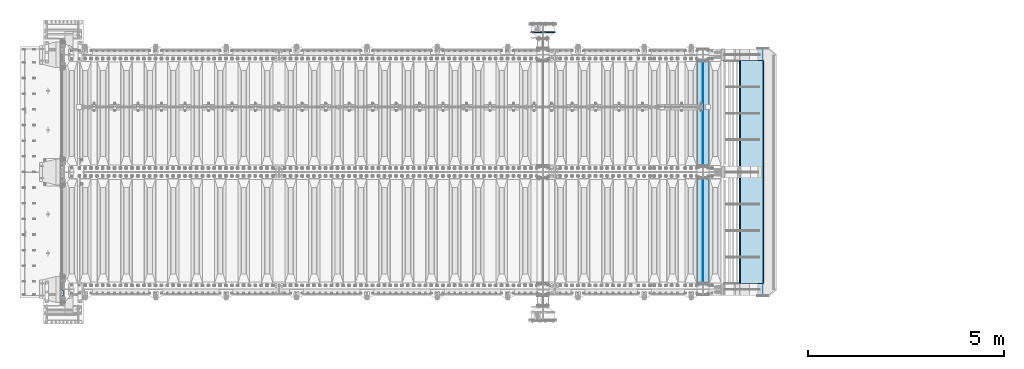
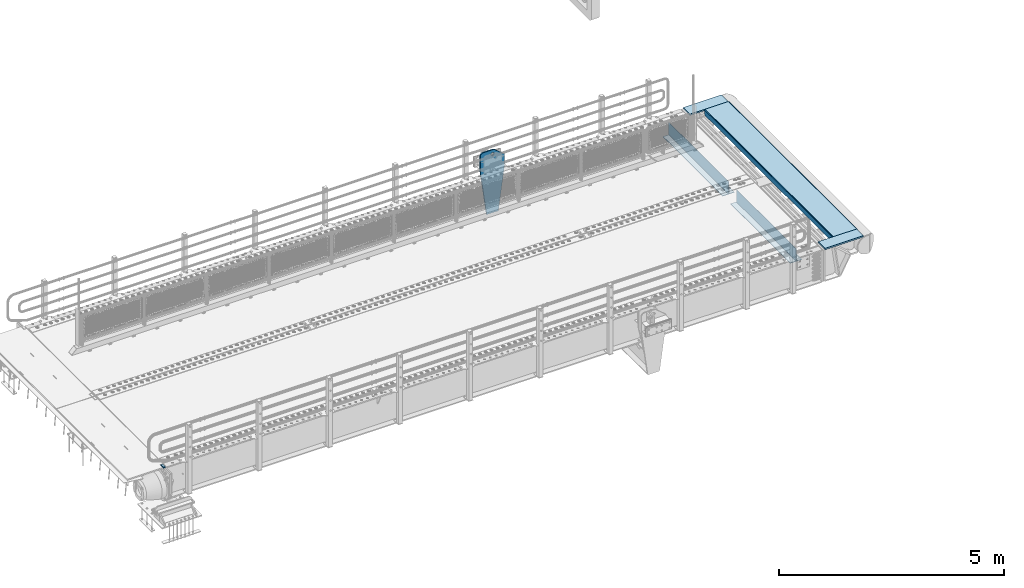
# One storey, part 165 of 208: 10 plates.
"""IFC2X3 building model written with IfcOpenShell, lengths in millimetres."""

import ifcopenshell
import ifcopenshell.guid

model = None  # the IFC model being written
_history = None  # IfcOwnerHistory: only IFC2X3 demands one
_inside = {}  # id of a spatial element -> (the spatial element, [elements in it])
_under = {}  # id of a project, library or spatial element -> (it, [spatial elements below it])
_declared = {}  # id of a project -> (the project, [libraries it declares])
_typed = {}  # id of a type object -> (the type object, [elements of that type])
_made_of = {}  # id of a material, layer set ... -> (it, [elements and type objects made of it])


def new_model(schema):
    """Start an empty IFC model of exactly this schema.

    Asked for "IFC4X3", IfcOpenShell would pick the latest addendum, in which some entities
    have other attributes; the version numbers below select the first issue.
    IFC2X3 requires an IfcOwnerHistory on every rooted entity: one is made here for all.
    """
    global model, _history
    if schema == "IFC4X3":
        model = ifcopenshell.file(schema_version=(4, 3, 0, 0))
    else:
        model = ifcopenshell.file(schema=schema)
    _inside.clear()
    _under.clear()
    _declared.clear()
    _typed.clear()
    _made_of.clear()
    _history = None
    if model.schema == "IFC2X3":
        org = make("IfcOrganization", Name="unknown")
        user = make(
            "IfcPersonAndOrganization",
            ThePerson=make("IfcPerson", FamilyName="unknown"),
            TheOrganization=org,
        )
        app = make(
            "IfcApplication",
            ApplicationDeveloper=org,
            Version="unknown",
            ApplicationFullName="unknown",
            ApplicationIdentifier="unknown",
        )
        _history = make(
            "IfcOwnerHistory",
            OwningUser=user,
            OwningApplication=app,
            ChangeAction="ADDED",
            CreationDate=0,
        )
    return model


def make(cls, **values):
    """One entity of the class cls with the attributes given. An attribute that is None is left unset."""
    return model.create_entity(
        cls, **{name: value for name, value in values.items() if value is not None}
    )


def rooted(cls, **values):
    """An entity with a GlobalId (a new one), such as an element, a storey or a relation."""
    return make(cls, GlobalId=ifcopenshell.guid.new(), OwnerHistory=_history, **values)


def si_unit(unit_type, name, prefix=None):
    """IfcSIUnit, for example si_unit("LENGTHUNIT", "METRE", prefix="MILLI")."""
    return make("IfcSIUnit", UnitType=unit_type, Prefix=prefix, Name=name)


def assignment(units):
    """IfcUnitAssignment: the units of a project."""
    return None if units is None else make("IfcUnitAssignment", Units=units)


def point(xyz):
    """IfcCartesianPoint."""
    return None if xyz is None else make("IfcCartesianPoint", Coordinates=xyz)


def direction(xyz):
    """IfcDirection."""
    return None if xyz is None else make("IfcDirection", DirectionRatios=xyz)


def frame(location, z_axis=None, x_axis=None):
    """IfcAxis2Placement3D, a coordinate frame: its origin and axes. An axis left out is left unset."""
    return make(
        "IfcAxis2Placement3D",
        Location=point(location),
        Axis=direction(z_axis),
        RefDirection=direction(x_axis),
    )


def origin_with_axes():
    """The frame at (0, 0, 0) with the z axis (0, 0, 1) and the x axis (1, 0, 0) written out."""
    return frame((0.0, 0.0, 0.0), z_axis=(0.0, 0.0, 1.0), x_axis=(1.0, 0.0, 0.0))


def place(relative_to, where):
    """IfcLocalPlacement: puts the frame where relative to a parent placement (None: the world)."""
    return make(
        "IfcLocalPlacement", PlacementRelTo=relative_to, RelativePlacement=where
    )


def context(
    kind, dimensions, precision=None, world=None, true_north=None, identifier=None
):
    """IfcGeometricRepresentationContext, for example the 3D "Model" context."""
    return make(
        "IfcGeometricRepresentationContext",
        ContextIdentifier=identifier,
        ContextType=kind,
        CoordinateSpaceDimension=dimensions,
        Precision=precision,
        WorldCoordinateSystem=world,
        TrueNorth=true_north,
    )


def subcontext(parent, identifier, kind, view, scale=None):
    """IfcGeometricRepresentationSubContext, for example "Body" below "Model"."""
    return make(
        "IfcGeometricRepresentationSubContext",
        ContextIdentifier=identifier,
        ContextType=kind,
        ParentContext=parent,
        TargetScale=scale,
        TargetView=view,
    )


def project(units=None, contexts=None):
    """IfcProject with its units and contexts."""
    return rooted(
        "IfcProject",
        Name="project",
        RepresentationContexts=contexts,
        UnitsInContext=assignment(units),
    )


def spatial(cls, under=None, at=None, **own):
    """A site, building, storey or space (cls), placed at a placement, below another one or the project."""
    s = rooted(cls, ObjectPlacement=at, **own)
    if under is not None:
        _under.setdefault(under.id(), (under, []))[1].append(s)
    return s


def faces_of(points, faces, orient=None, outer=None):
    """IfcFace entities. A face is a list of loops; a loop is a list of indices into points, from 0.

    orient and outer hold one flag for each loop. By default every Orientation is true, the
    first loop of a face is its IfcFaceOuterBound and the others are IfcFaceBound.
    """
    made = []
    for i, loops in enumerate(faces):
        bounds = []
        for j, loop in enumerate(loops):
            is_outer = j == 0 if outer is None else outer[i][j]
            bounds.append(
                make(
                    "IfcFaceOuterBound" if is_outer else "IfcFaceBound",
                    Bound=make("IfcPolyLoop", Polygon=[points[k] for k in loop]),
                    Orientation=True if orient is None else orient[i][j],
                )
            )
        made.append(make("IfcFace", Bounds=bounds))
    return made


def faceted_brep(points, faces, orient=None, outer=None, voids=None):
    """IfcFacetedBrep: a solid bounded by flat faces; with voids (closed shells), ...WithVoids."""
    shared = [point(p) for p in points]
    hull = make("IfcClosedShell", CfsFaces=faces_of(shared, faces, orient, outer))
    if voids is None:
        return make("IfcFacetedBrep", Outer=hull)
    return make(
        "IfcFacetedBrepWithVoids",
        Outer=hull,
        Voids=[
            make(cls, CfsFaces=faces_of(shared, fs, o, b)) for cls, fs, o, b in voids
        ],
    )


def shape(context_of_items, identifier, shape_type, items):
    """IfcShapeRepresentation: the items that make up one representation, for example the "Body"."""
    return make(
        "IfcShapeRepresentation",
        ContextOfItems=context_of_items,
        RepresentationIdentifier=identifier,
        RepresentationType=shape_type,
        Items=items,
    )


def material(Name=None, Category=None):
    """IfcMaterial."""
    return make("IfcMaterial", Name=Name, Category=Category)


def made_of(thing, what):
    """Note that an element or type object is made of a material, layer set ...; save() writes the relation."""
    if what is not None:
        _made_of.setdefault(what.id(), (what, []))[1].append(thing)
    return thing


def type_object(cls, material=None, **own):
    """A type object (cls), such as IfcWallType, which elements share."""
    return made_of(rooted(cls, **own), material)


def element(
    cls,
    number,
    at=None,
    inside=None,
    cuts=None,
    type_object=None,
    material=None,
    context=None,
    identifier="Body",
    shape_type=None,
    held_by="IfcProductDefinitionShape",
    body=None,
    shapes=None,
    **own,
):
    """One element of the class cls, such as IfcWall. Its Tag is "e" and its number.

    at: its placement. inside: the storey or other place that contains it. cuts: it is an
    opening in that element (IfcRelVoidsElement). A single representation is given by context,
    identifier, shape_type and body (its items); several are given by shapes. held_by: the class
    of the entity that holds the representations. save() writes the other relations.
    """
    e = rooted(cls, Tag="e%d" % number, ObjectPlacement=at, **own)
    if body is not None:
        shapes = [shape(context, identifier, shape_type, body)]
    if shapes is not None:
        e.Representation = make(held_by, Representations=shapes)
    if inside is not None:
        _inside.setdefault(inside.id(), (inside, []))[1].append(e)
    if cuts is not None:
        rooted(
            "IfcRelVoidsElement", RelatingBuildingElement=cuts, RelatedOpeningElement=e
        )
    if type_object is not None:
        _typed.setdefault(type_object.id(), (type_object, []))[1].append(e)
    return made_of(e, material)


def aggregate(whole, parts):
    """IfcRelAggregates: a whole, such as a stair, and the parts it consists of."""
    return rooted("IfcRelAggregates", RelatingObject=whole, RelatedObjects=parts)


def save(model, path):
    """Write the relations noted so far, then the file.

    IfcRelAggregates (storeys below a building ...), IfcRelContainedInSpatialStructure (elements
    in a storey), IfcRelDefinesByType, IfcRelAssociatesMaterial and IfcRelDeclares: one each for
    every whole, place, type object, material and project.
    """
    for whole, parts in _under.values():
        aggregate(whole, parts)
    for where, things in _inside.values():
        rooted(
            "IfcRelContainedInSpatialStructure",
            RelatedElements=things,
            RelatingStructure=where,
        )
    for kind, things in _typed.values():
        rooted("IfcRelDefinesByType", RelatedObjects=things, RelatingType=kind)
    for what, things in _made_of.values():
        rooted("IfcRelAssociatesMaterial", RelatedObjects=things, RelatingMaterial=what)
    for by, libraries in _declared.values():
        rooted("IfcRelDeclares", RelatingContext=by, RelatedDefinitions=libraries)
    model.write(path)


model = new_model("IFC2X3")

# Units and contexts
model_context = context("Model", 3, precision=1e-05, world=origin_with_axes())
body_context = subcontext(model_context, "Body", "Model", "MODEL_VIEW")
ifc_project = project(units=[si_unit("LENGTHUNIT", "METRE", prefix="MILLI"), si_unit("AREAUNIT", "SQUARE_METRE"), si_unit("VOLUMEUNIT", "CUBIC_METRE"), si_unit("MASSUNIT", "GRAM", prefix="KILO"), si_unit("TIMEUNIT", "SECOND"), si_unit("PLANEANGLEUNIT", "RADIAN"), si_unit("SOLIDANGLEUNIT", "STERADIAN"), si_unit("THERMODYNAMICTEMPERATUREUNIT", "DEGREE_CELSIUS"), si_unit("LUMINOUSINTENSITYUNIT", "LUMEN")], contexts=[model_context])

# Site, building, storey
site_placement = place(None, origin_with_axes())
site = spatial("IfcSite", under=ifc_project, at=site_placement, CompositionType="ELEMENT")
building_placement = place(site_placement, origin_with_axes())
building = spatial("IfcBuilding", under=site, at=building_placement, Name="Standard", CompositionType="ELEMENT")
storey_placement = place(building_placement, origin_with_axes())
storey = spatial("IfcBuildingStorey", under=building, at=storey_placement, Name="Undefined", CompositionType="ELEMENT", Elevation=0.0)

# Plates
ifc_material_1 = material()
plate_type_1 = type_object("IfcPlateType", PredefinedType="NOTDEFINED")
plate_1_placement = place(storey_placement, frame((-42460.00000006, -89.9999995680091, -15.9997623858373), z_axis=(-1.0, 0.0, 0.0), x_axis=(0.0, -4.95099999998473e-06, 0.999999999987744)))
element("IfcPlate", 1, at=plate_1_placement, inside=storey, type_object=plate_type_1, material=ifc_material_1, context=body_context, shape_type="Brep", body=[
    faceted_brep([(-1.77635683940025e-15, -60.0, 0.0), (-0.000933120085690575, -60.0, 60.0), (-0.000933120085690575, 60.0, 59.9999999999927), (-1.77635683940025e-15, 60.0, -7.27595761418343e-12), (24.9991450303709, -60.0, 60.0), (24.9991450303709, 60.0, 59.9999999999927), (26.544215218168, -60.0, 59.7552873850873), (26.544215218168, 60.0, 59.75528738508), (27.9380461396139, -60.0, 59.0451032459096), (27.9380461396139, 60.0, 59.0451032459096), (29.0442025908961, -60.0, 57.9389639895744), (29.0442025908961, 60.0, 57.9389639895744), (29.7544083969366, -60.0, 56.5451441080368), (29.7544083969366, 60.0, 56.5451441080295), (29.9991450297669, -60.0, 55.0000777244568), (29.9991450297669, 60.0, 55.0000777244495), (29.999922274335, -60.0, 5.00007772445679), (29.999922274335, 60.0, 5.00007772444951), (29.7552240705896, -60.0, 3.45497416452417), (29.7552240705896, 60.0, 3.45497416452417), (29.0450346578116, -60.0, 2.06111146690819), (29.0450346578116, 60.0, 2.06111146690819), (27.9388736885072, -60.0, 0.954933302316931), (27.9388736885072, 60.0, 0.954933302316931), (26.5450220308766, -60.0, 0.244722222181736), (26.5450220308766, 60.0, 0.244722222181736), (24.9999222749392, -60.0, 0.0), (24.9999222749392, 60.0, -7.27595761418343e-12)], [[[0, 1, 2, 3]], [[1, 4, 5, 2]], [[4, 6, 7, 5]], [[6, 8, 9, 7]], [[8, 10, 11, 9]], [[10, 12, 13, 11]], [[12, 14, 15, 13]], [[14, 16, 17, 15]], [[16, 18, 19, 17]], [[18, 20, 21, 19]], [[20, 22, 23, 21]], [[22, 24, 25, 23]], [[24, 26, 27, 25]], [[26, 0, 3, 27]], [[5, 7, 9, 11, 13, 15, 17, 19, 21, 23, 25, 27, 3, 2]], [[26, 24, 22, 20, 18, 16, 14, 12, 10, 8, 6, 4, 1, 0]]]),
])
ifc_material_2 = material(Name="STEEL/S355N")
plate_type_2 = type_object("IfcPlateType", PredefinedType="NOTDEFINED")
for number, where, z_axis, x_axis in (
    (2, (-26255.0, 175.0, -343.0), (0.0, 1.0, 0.0), (1.0, 0.0, 0.0)),
    (3, (-26255.0, 3175.0, -343.0), (0.0, 1.0, 0.0), (1.0, 0.0, 0.0)),
):
    element("IfcPlate", number, at=place(storey_placement, frame(where, z_axis=z_axis, x_axis=x_axis)), inside=storey, type_object=plate_type_2, material=ifc_material_2, context=body_context, shape_type="Brep", body=[
        faceted_brep([(0.0, -7.0, 0.0), (0.0, -7.0, 2650.0), (0.0, 7.0, 2650.0), (0.0, 7.0, 0.0), (300.0, -7.0, 2650.0), (300.0, 7.0, 2650.0), (300.0, -7.0, 0.0), (300.0, 7.0, 0.0)], [[[0, 1, 2, 3]], [[1, 4, 5, 2]], [[4, 6, 7, 5]], [[6, 0, 3, 7]], [[5, 7, 3, 2]], [[6, 4, 1, 0]]]),
    ])
plate_type_3 = type_object("IfcPlateType", PredefinedType="NOTDEFINED")
for number, where, z_axis, x_axis in (
    (4, (-26105.0, 2825.0, 0.0), (0.0, 0.0, -1.0), (0.0, -1.0, 0.0)),
    (5, (-26105.0, 5825.0, 0.0), (0.0, 0.0, -1.0), (0.0, -1.0, 0.0)),
):
    element("IfcPlate", number, at=place(storey_placement, frame(where, z_axis=z_axis, x_axis=x_axis)), inside=storey, type_object=plate_type_3, material=ifc_material_2, context=body_context, shape_type="Brep", body=[
        faceted_brep([(0.0, -5.0, 0.0), (0.0, -5.0, 336.0), (0.0, 5.0, 336.0), (0.0, 5.0, 0.0), (2650.0, -5.0, 336.0), (2650.0, 5.0, 336.0), (2650.0, -5.0, 0.0), (2650.0, 5.0, 0.0)], [[[0, 1, 2, 3]], [[1, 4, 5, 2]], [[4, 6, 7, 5]], [[6, 0, 3, 7]], [[5, 7, 3, 2]], [[6, 4, 1, 0]]]),
    ])
plate_type_4 = type_object("IfcPlateType", PredefinedType="NOTDEFINED")
plate_2_placement = place(storey_placement, frame((-30050.0000000603, 6580.00000003457, -1470.00001822199), z_axis=(0.0, 0.0, 1.0), x_axis=(-1.0, 0.0, 0.0)))
element("IfcPlate", 6, at=plate_2_placement, inside=storey, type_object=plate_type_4, material=ifc_material_2, context=body_context, shape_type="Brep", body=[
    faceted_brep([(113.04481869996, -15.0, 1615.3073372946), (113.04481869996, 14.999999999953, 1615.3073372946), (121.715728752948, 14.999999999953, 1628.28427124746), (121.715728752948, -15.0, 1628.28427124746), (134.692662705809, 14.999999999953, 1636.95518130045), (134.692662705809, -15.0, 1636.95518130045), (150.000000000411, 14.999999999953, 1640.0), (150.000000000411, -15.0, 1640.0), (165.307337295013, 14.999999999953, 1636.95518130045), (165.307337295013, -15.0, 1636.95518130045), (178.284271247874, 14.999999999953, 1628.28427124746), (178.284271247874, -15.0, 1628.28427124746), (186.955181300862, 14.999999999953, 1615.3073372946), (186.955181300862, -15.0, 1615.3073372946), (190.000000000411, 14.999999999953, 1600.0), (190.000000000411, -15.0, 1600.0), (186.955181300862, 14.999999999953, 1584.6926627054), (186.955181300862, -15.0, 1584.6926627054), (178.284271247874, 14.999999999953, 1571.71572875254), (178.284271247874, -15.0, 1571.71572875254), (165.307337295013, 14.999999999953, 1563.04481869955), (165.307337295013, -15.0, 1563.04481869955), (150.000000000411, 14.999999999953, 1560.0), (150.000000000411, -15.0, 1560.0), (134.692662705809, 14.999999999953, 1563.04481869955), (134.692662705809, -15.0, 1563.04481869955), (121.715728752948, 14.999999999953, 1571.71572875254), (121.715728752948, -15.0, 1571.71572875254), (113.04481869996, 14.999999999953, 1584.6926627054), (113.04481869996, -15.0, 1584.6926627054), (110.000000000411, 14.999999999953, 1600.0), (110.000000000411, -15.0, 1600.0), (300.0, -15.0, 0.0), (0.0, -15.0, 0.0), (0.0, 15.0, 0.0), (300.0, 15.0, 0.0), (462.5, -15.0, 1210.0), (462.5, 15.0, 1210.0), (462.5, -15.0, 1630.0), (462.5, 15.0, 1630.0), (459.774066103124, -15.0, 1650.7055236082), (459.774066103124, 15.0, 1650.7055236082), (451.782032302755, -15.0, 1670.0), (451.782032302755, 15.0, 1670.0), (439.068542494922, -15.0, 1686.56854249492), (439.068542494922, 15.0, 1686.56854249492), (422.5, -15.0, 1699.28203230276), (422.5, 15.0, 1699.28203230276), (403.205523608201, -15.0, 1707.27406610313), (403.205523608201, 15.0, 1707.27406610313), (382.5, -15.0, 1710.0), (382.5, 15.0, 1710.0), (151.788081037081, -15.0, 1710.0), (151.788081037081, 15.0, 1710.0), (132.694887325029, -15.0, 1708.33028179541), (132.694887325029, 15.0, 1708.33028179541), (114.181334578883, -15.0, 1703.37181734316), (114.181334578883, 15.0, 1703.37181734316), (96.809466726856, -15.0, 1695.27513824985), (96.809466726856, 15.0, 1695.27513824985), (81.1066678416755, -15.0, 1684.28604765144), (81.1066678416755, 15.0, 1684.28604765144), (-162.5, -15.0, 1480.0), (-162.5, 15.0, 1480.0), (-162.5, -15.0, 1210.0), (-162.5, 15.0, 1210.0), (150.000000000411, -14.9999999999999, 1551.5), (154.596194078124, -14.9999999999999, 1549.59619407771), (156.500000000411, -14.9999999999999, 1545.0), (154.596194078124, -14.9999999999999, 1540.40380592229), (150.000000000411, -14.9999999999999, 1538.5), (145.403805922699, -14.9999999999999, 1540.40380592229), (143.500000000411, -14.9999999999999, 1545.0), (145.403805922699, -14.9999999999999, 1549.59619407771), (150.000000000411, 15.0, 1538.5), (145.403805922699, 15.0, 1540.40380592229), (154.596194078124, 15.0, 1540.40380592229), (156.500000000411, 15.0, 1545.0), (154.596194078124, 15.0, 1549.59619407771), (150.000000000411, 15.0, 1551.5), (145.403805922699, 15.0, 1549.59619407771), (143.500000000411, 15.0, 1545.0)], [[[0, 1, 2, 3]], [[3, 2, 4, 5]], [[5, 4, 6, 7]], [[7, 6, 8, 9]], [[9, 8, 10, 11]], [[11, 10, 12, 13]], [[13, 12, 14, 15]], [[15, 14, 16, 17]], [[17, 16, 18, 19]], [[19, 18, 20, 21]], [[21, 20, 22, 23]], [[23, 22, 24, 25]], [[25, 24, 26, 27]], [[27, 26, 28, 29]], [[29, 28, 30, 31]], [[31, 30, 1, 0]], [[32, 33, 34, 35]], [[36, 32, 35, 37]], [[38, 36, 37, 39]], [[40, 38, 39, 41]], [[42, 40, 41, 43]], [[44, 42, 43, 45]], [[46, 44, 45, 47]], [[48, 46, 47, 49]], [[50, 48, 49, 51]], [[52, 50, 51, 53]], [[54, 52, 53, 55]], [[56, 54, 55, 57]], [[58, 56, 57, 59]], [[60, 58, 59, 61]], [[62, 60, 61, 63]], [[64, 62, 63, 65]], [[33, 64, 65, 34]], [[32, 36, 38, 40, 42, 44, 46, 48, 50, 52, 54, 56, 58, 60, 62, 64, 33], [3, 5, 7, 9, 11, 13, 15, 17, 19, 21, 23, 25, 27, 29, 31, 0], [66, 67, 68, 69, 70, 71, 72, 73]], [[70, 74, 75, 71]], [[69, 76, 74, 70]], [[68, 77, 76, 69]], [[67, 78, 77, 68]], [[66, 79, 78, 67]], [[73, 80, 79, 66]], [[72, 81, 80, 73]], [[71, 75, 81, 72]], [[63, 61, 59, 57, 55, 53, 51, 49, 47, 45, 43, 41, 39, 37, 35, 34, 65], [26, 24, 22, 20, 18, 16, 14, 12, 10, 8, 6, 4, 2, 1, 30, 28], [74, 76, 77, 78, 79, 80, 81, 75]]]),
])
plate_type_5 = type_object("IfcPlateType", PredefinedType="NOTDEFINED")
for number, where, z_axis, x_axis in (
    (7, (-25553.0011701094, 150.0, -10.0000000001684), (1.0, 0.0, 0.0), (0.0, -1.0, 0.0)),
    (8, (-25553.0011701095, 6150.0, -10.0000000004865), (1.0, 0.0, 0.0), (0.0, -1.0, 0.0)),
):
    element("IfcPlate", number, at=place(storey_placement, frame(where, z_axis=z_axis, x_axis=x_axis)), inside=storey, type_object=plate_type_5, material=ifc_material_2, context=body_context, shape_type="Brep", body=[
        faceted_brep([(300.0, 7.0, 986.0), (300.0, 20.0, 956.0), (-3.35091954184463e-11, 20.0, 956.0), (-3.45607986673713e-11, 7.0, 986.0), (0.0, 20.0, 0.0), (0.0, -20.0, 0.0), (-3.45607986673713e-11, -20.0, 986.0), (300.0, -20.0, 986.0), (300.0, -20.0, 3.63797880709171e-12), (300.0, 20.0, 3.63797880709171e-12)], [[[0, 1, 2, 3]], [[4, 5, 6, 3, 2]], [[6, 7, 0, 3]], [[7, 8, 9, 1, 0]], [[8, 5, 4, 9]], [[9, 4, 2, 1]], [[8, 7, 6, 5]]]),
    ])
plate_type_6 = type_object("IfcPlateType", PredefinedType="NOTDEFINED")
plate_3_placement = place(storey_placement, frame((-25159.4454489358, 5850.00000000159, -155.274111776635), z_axis=(0.0, -1.0, 0.0), x_axis=(-0.0871556999853763, 0.0, 0.99619470183296)))
element("IfcPlate", 9, at=plate_3_placement, inside=storey, type_object=plate_type_6, material=ifc_material_2, context=body_context, shape_type="Brep", body=[
    faceted_brep([(0.0, -10.0, 0.0), (4.54747350886464e-13, -9.99999999999636, 5700.0), (4.54747350886464e-13, 9.99999999999636, 5700.0), (0.0, 10.0, 0.0), (155.0, -9.99999999999636, 5700.0), (155.0, 10.0, 5700.0), (155.0, -9.99999999999636, 0.0), (155.0, 10.0, 0.0)], [[[0, 1, 2, 3]], [[1, 4, 5, 2]], [[4, 6, 7, 5]], [[6, 0, 3, 7]], [[5, 7, 3, 2]], [[6, 4, 1, 0]]]),
])
plate_type_7 = type_object("IfcPlateType", PredefinedType="NOTDEFINED")
plate_4_placement = place(storey_placement, frame((-25162.997031974, 5850.00000000154, 0.00398537333359705), z_axis=(0.999999999979944, 6.48999999598972e-07, -6.29999999987365e-06), x_axis=(0.0, -1.0, 0.0)))
element("IfcPlate", 10, at=plate_4_placement, inside=storey, type_object=plate_type_7, material=ifc_material_2, context=body_context, shape_type="Brep", body=[
    faceted_brep([(5700.00047245355, -10.0, 596.995666503903), (5700.00048828125, 5.78898040615172e-13, 616.99566650391), (0.000205278951398213, 5.77649039712469e-13, 616.995788574219), (0.00019862480712618, -10.0, 596.995788574215), (0.000205278951398213, 10.0, 616.995788574219), (0.0, 10.0, 0.0), (0.0, -10.0, 0.0), (5700.00048828125, 10.0, 616.99566650391), (5700.0, -10.0, 2.17187334783375e-09), (5700.0, 10.0, 2.17551132664084e-09)], [[[0, 1, 2, 3]], [[4, 5, 6, 3, 2]], [[7, 4, 2, 1]], [[8, 9, 7, 1, 0]], [[8, 6, 5, 9]], [[7, 9, 5, 4]], [[6, 8, 0, 3]]]),
])

save(model, "model.ifc")
